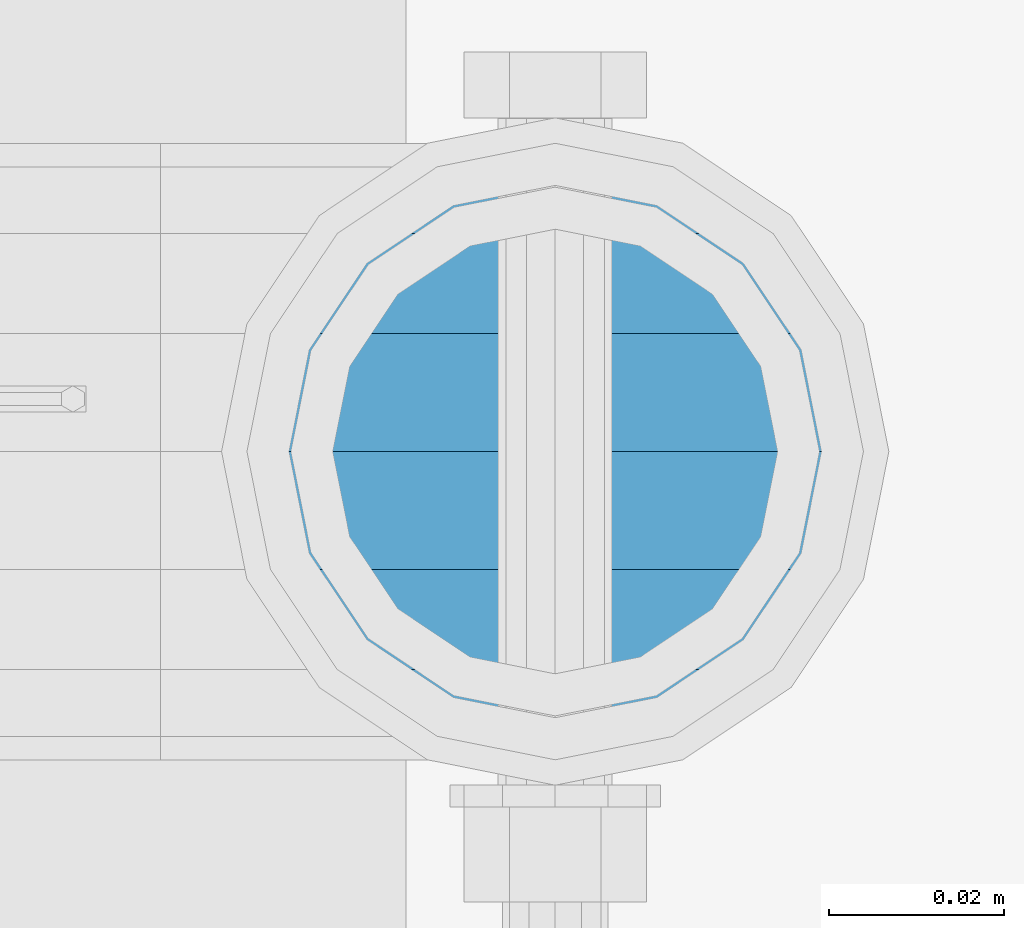
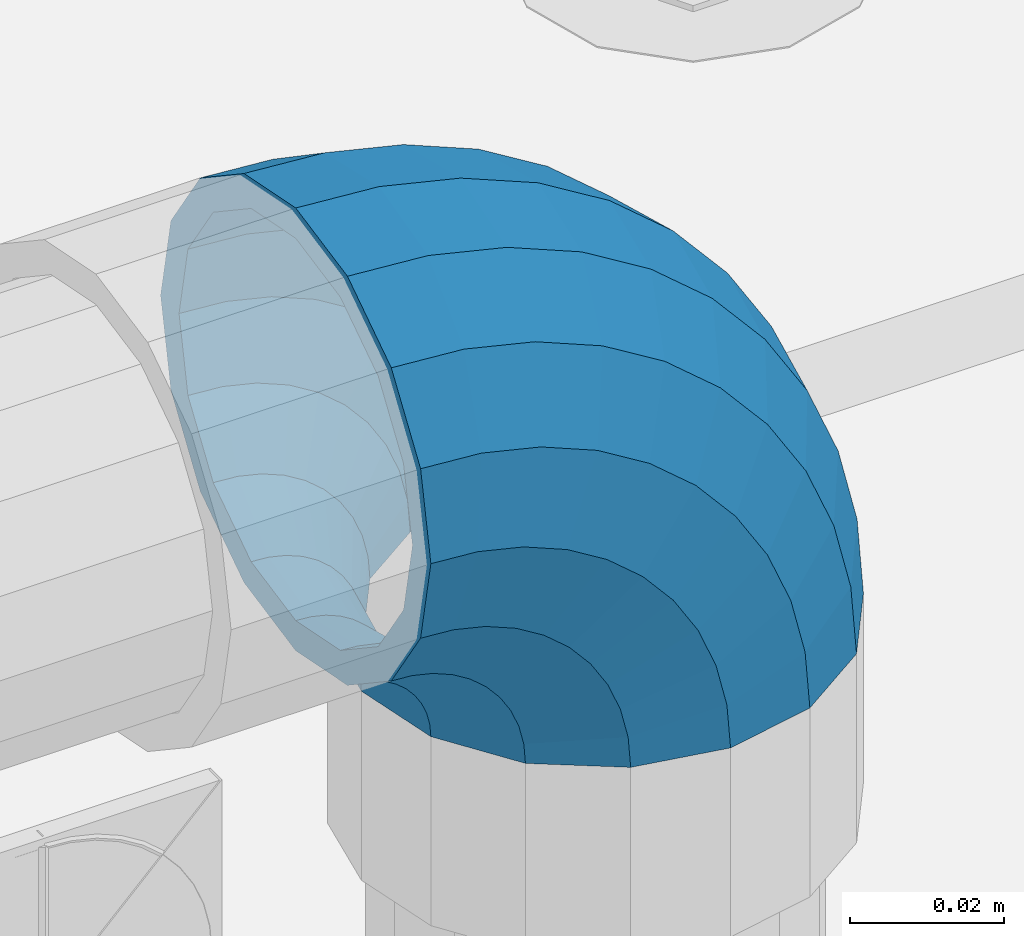
# One storey, part 159 of 240: 1 member.
"""IFC2X3 building model written with IfcOpenShell, lengths in millimetres."""

from ifc_helpers import new_model, si_unit, frame, origin_with_axes, place, context, subcontext, project, spatial, faceted_brep, material, type_object, element, save


model = new_model("IFC2X3")

# Units and contexts
model_context = context("Model", 3, precision=1e-05, world=origin_with_axes())
body_context = subcontext(model_context, "Body", "Model", "MODEL_VIEW")
ifc_project = project(units=[si_unit("LENGTHUNIT", "METRE", prefix="MILLI"), si_unit("AREAUNIT", "SQUARE_METRE"), si_unit("VOLUMEUNIT", "CUBIC_METRE"), si_unit("MASSUNIT", "GRAM", prefix="KILO"), si_unit("TIMEUNIT", "SECOND"), si_unit("PLANEANGLEUNIT", "RADIAN"), si_unit("SOLIDANGLEUNIT", "STERADIAN"), si_unit("THERMODYNAMICTEMPERATUREUNIT", "DEGREE_CELSIUS"), si_unit("LUMINOUSINTENSITYUNIT", "LUMEN")], contexts=[model_context])

# Site, building, storey
site_placement = place(None, origin_with_axes())
site = spatial("IfcSite", under=ifc_project, at=site_placement, CompositionType="ELEMENT")
building_placement = place(site_placement, origin_with_axes())
building = spatial("IfcBuilding", under=site, at=building_placement, Name="Standard", CompositionType="ELEMENT")
storey_placement = place(building_placement, origin_with_axes())
storey = spatial("IfcBuildingStorey", under=building, at=storey_placement, Name="Undefined", CompositionType="ELEMENT", Elevation=0.0)

# Member
ifc_material = material(Name="Misc_Undefined")
member_type = type_object("IfcMemberType", PredefinedType="NOTDEFINED")
member_placement = place(storey_placement, frame((54677.0, 34664.5, 924.85), z_axis=(0.707106781186541, -1.49999999888231e-07, 0.707106781186538), x_axis=(-0.707106781186548, 0.0, 0.707106781186548)))
element("IfcMember", 1, at=member_placement, inside=storey, type_object=member_type, material=ifc_material, context=body_context, shape_type="Brep", body=[
    faceted_brep([(0.0, -35.1500000000015, 0.0), (9.51152146006643, -32.4743655677739, -9.51152146006643), (13.2759578763362, -32.4743655677739, -6.29638902527222), (5.36946880023606, -35.1500000000015, 4.58595959348168), (17.5749999999971, -24.8548033587067, -17.5749999999971), (19.9787556631127, -24.8548033587067, -15.5219987155579), (22.9628441077002, -13.4513226476338, -22.9628441077002), (24.4574219585265, -13.4513226476338, -21.686354032383), (24.8548033587067, 0.0, -24.8548033587067), (26.0301204183124, 0.0, -23.8509877588003), (22.9628441077002, 13.4513226476338, -22.9628441077002), (24.4574219585265, 13.4513226476338, -21.686354032383), (17.5749999999971, 24.8548033587067, -17.5749999999971), (19.9787556631127, 24.8548033587067, -15.5219987155579), (9.51152146006643, 32.4743655677739, -9.51152146006643), (13.2759578763362, 32.4743655677739, -6.29638902527222), (0.0, 35.1500000000015, 0.0), (5.36946880023606, 35.1500000000015, 4.58595959348168), (-9.51152146007371, 32.4743655677739, 9.51152146007371), (-2.53702027587133, 32.4743655677739, 15.4683082122356), (-17.5749999999971, 24.8548033587067, 17.5750000000044), (-9.23981806264055, 24.8548033587067, 24.6939179025212), (-22.9628441077075, 13.4513226476338, 22.9628441077075), (-13.7184843580544, 13.4513226476338, 30.8582732193609), (-24.8548033587067, 0.0, 24.854803358714), (-15.2911828178476, 0.0, 33.0229069457637), (-22.9628441077075, -13.4513226476338, 22.9628441077075), (-13.7184843580544, -13.4513226476338, 30.8582732193609), (-17.5749999999971, -24.8548033587067, 17.5750000000044), (-9.23981806264055, -24.8548033587067, 24.6939179025212), (-9.51152146007371, -32.4743655677739, 9.51152146007371), (-2.53702027587133, -32.4743655677739, 15.4683082122356), (0.0, -30.3499999999985, 0.0), (-8.21265081971796, -28.0397438117143, 8.21265081971796), (-1.45732902223244, -28.0397438117143, 13.9822406910389), (5.36946880023606, -30.3499999999985, 4.58595959348168), (-15.1750000000029, -21.4606908090136, 15.1750000000029), (-7.24480876131565, -21.4606908090136, 21.9480231689959), (-19.8270929919963, -11.6144421722784, 19.8270929919963), (-11.1118790903492, -11.6144421722784, 27.2705888550845), (-21.4606908090136, 0.0, 21.4606908090136), (-12.46981360684, 0.0, 29.139625372758), (-19.8270929919963, 11.6144421722784, 19.8270929919963), (-11.1118790903492, 11.6144421722784, 27.2705888550845), (-15.1750000000029, 21.4606908090136, 15.1750000000029), (-7.24480876131565, 21.4606908090136, 21.9480231689959), (-8.21265081971796, 28.0397438117143, 8.21265081971796), (-1.45732902223244, 28.0397438117143, 13.9822406910389), (0.0, 30.3499999999985, 0.0), (5.36946880023606, 30.3499999999985, 4.58595959348168), (8.21265081971796, 28.0397438117143, -8.21265081971796), (12.1962666227046, 28.0397438117143, -4.81032150407555), (15.1750000000029, 21.4606908090136, -15.1749999999956), (17.9837463617805, 21.4606908090136, -12.7761039820398), (19.8270929919963, 11.6144421722784, -19.8270929919963), (21.8508166908287, 11.6144421722784, -18.0986696681139), (21.4606908090136, 0.0, -21.4606908090063), (23.2087512073122, 0.0, -19.9677061857947), (19.8270929919963, -11.6144421722784, -19.8270929919963), (21.8508166908287, -11.6144421722784, -18.0986696681139), (15.1750000000029, -21.4606908090136, -15.1749999999956), (17.9837463617805, -21.4606908090136, -12.7761039820398), (8.21265081971796, -28.0397438117143, -8.21265081971796), (12.1962666227046, -28.0397438117143, -4.81032150407555), (17.4970053560755, -32.4743655677739, -3.70972780291777), (11.390232665115, -35.1500000000015, 8.27548843508703), (22.6740772628618, -24.8548033587067, -13.8703035149447), (26.1332861179544, -13.4513226476338, -20.6593831546707), (27.347998730962, 0.0, -23.0433908901396), (26.1332861179544, 13.4513226476338, -20.6593831546707), (22.6740772628618, 24.8548033587067, -13.8703035149447), (17.4970053560755, 32.4743655677739, -3.70972780291777), (11.390232665115, 35.1500000000015, 8.27548843508703), (5.28345997416181, 32.4743655677739, 20.2607046730918), (0.106388067375519, 24.8548033587067, 30.4212803851042), (-3.35282078771706, 13.4513226476338, 37.210360024852), (-4.56753340072464, 0.0, 39.5943677603063), (-3.35282078771706, -13.4513226476338, 37.210360024852), (0.106388067375519, -24.8548033587067, 30.4212803851042), (5.28345997416181, -32.4743655677739, 20.2607046730918), (6.11738625913131, -28.0397438117143, 18.6240321853984), (11.390232665115, -30.3499999999985, 8.27548843508703), (1.64728291997744, -21.4606908090136, 27.3971039595053), (-1.33954464053386, -11.6144421722784, 33.2590831078996), (-2.38837900197541, 0.0, 35.3175364442068), (-1.33954464053386, 11.6144421722784, 33.2590831078996), (1.64728291997744, 21.4606908090136, 27.3971039595053), (6.11738625913131, 28.0397438117143, 18.6240321853984), (11.390232665115, 30.3499999999985, 8.27548843508703), (16.663079071106, 28.0397438117143, -2.07305531522434), (21.1331824102599, 21.4606908090136, -10.8461270893313), (24.1200099707639, 11.6144421722784, -16.7081062377256), (25.1688443322128, 0.0, -18.7665595740255), (24.1200099707639, -11.6144421722784, -16.7081062377256), (21.1331824102599, -21.4606908090136, -10.8461270893313), (16.663079071106, -28.0397438117143, -2.07305531522434), (22.070727701459, -32.4743655677739, -1.81522997692809), (17.9140404065256, -35.1500000000015, 10.9777380798914), (25.5945970362081, -24.8548033587067, -12.6605846156453), (27.9491712485105, -13.4513226476338, -19.9072189058861), (28.7759877588032, 0.0, -22.4518984678798), (27.9491712485105, 13.4513226476338, -19.9072189058861), (25.5945970362081, 24.8548033587067, -12.6605846156453), (22.070727701459, 32.4743655677739, -1.81522997692809), (17.9140404065256, 35.1500000000015, 10.9777380798914), (13.7573531115777, 32.4743655677739, 23.7707061367109), (10.2334837768358, 24.8548033587067, 34.6160607754209), (7.87890956454066, 13.4513226476338, 41.862695065669), (7.05209305424796, 0.0, 44.4073746276699), (7.87890956454066, -13.4513226476338, 41.862695065669), (10.2334837768358, -24.8548033587067, 34.6160607754209), (13.7573531115777, -32.4743655677739, 23.7707061367109), (14.3249803951039, -28.0397438117143, 22.023728990971), (17.9140404065256, -30.3499999999985, 10.9777380798914), (11.2823222355146, -21.4606908090136, 31.3880679180002), (9.24928305078356, -11.6144421722784, 37.6451191472734), (8.53537462724489, 0.0, 39.8423033494473), (9.24928305078356, 11.6144421722784, 37.6451191472734), (11.2823222355146, 21.4606908090136, 31.3880679180002), (14.3249803951039, 28.0397438117143, 22.023728990971), (17.9140404065256, 30.3499999999985, 10.9777380798914), (21.5031004179473, 28.0397438117143, -0.0682528311954229), (24.5457585775293, 21.4606908090136, -9.43259175821731), (26.5787977622676, 11.6144421722784, -15.6896429874905), (27.2927061858063, 0.0, -17.8868271896717), (26.5787977622676, -11.6144421722784, -15.6896429874905), (24.5457585775293, -21.4606908090136, -9.43259175821731), (21.5031004179473, -28.0397438117143, -0.0682528311954229), (26.8845046890492, -32.4743655677739, -0.659544371257653), (24.7802542265854, -35.1500000000015, 12.6261701733893), (28.6684020936882, -24.8548033587067, -11.9226293117827), (29.860364231703, -13.4513226476338, -19.4483820661189), (30.2789256727556, 0.0, -22.0910749985269), (29.860364231703, 13.4513226476338, -19.4483820661189), (28.6684020936882, 24.8548033587067, -11.9226293117827), (26.8845046890492, 32.4743655677739, -0.659544371257653), (24.7802542265854, 35.1500000000015, 12.6261701733893), (22.6760037641216, 32.4743655677739, 25.9118847180362), (20.8921063594826, 24.8548033587067, 37.1749696585684), (19.7001442214678, 13.4513226476338, 44.7007224129047), (19.2815827804225, 0.0, 47.3434153453127), (19.7001442214678, -13.4513226476338, 44.7007224129047), (20.8921063594826, -24.8548033587067, 37.1749696585684), (22.6760037641216, -32.4743655677739, 25.9118847180362), (22.9633551786319, -28.0397438117143, 24.0976192894668), (24.7802542265854, -30.3499999999985, 12.6261701733893), (21.4230625404889, -21.4606908090136, 33.8226442665691), (20.3938719035359, -11.6144421722784, 40.3206982095071), (20.0324682126156, 0.0, 42.6025113104479), (20.3938719035359, 11.6144421722784, 40.3206982095071), (21.4230625404889, 21.4606908090136, 33.8226442665691), (22.9633551786319, 28.0397438117143, 24.0976192894668), (24.7802542265854, 30.3499999999985, 12.6261701733893), (26.5971532745461, 28.0397438117143, 1.15472105731169), (28.1374459126891, 21.4606908090136, -8.57030391978333), (29.1666365496349, 11.6144421722784, -15.0683578627213), (29.5280402405551, 0.0, -17.3501709636694), (29.1666365496349, -11.6144421722784, -15.0683578627213), (28.1374459126891, -21.4606908090136, -8.57030391978333), (26.5971532745461, -28.0397438117143, 1.15472105731169), (31.8198051533982, -32.4743655677739, -0.271127801024704), (31.8198051533909, -35.1500000000015, 13.1801948466091), (31.8198051533982, -24.8548033587067, -11.6746085120976), (31.8198051533909, -13.4513226476338, -19.2941707211648), (31.8198051533982, 0.0, -21.9698051533924), (31.8198051533909, 13.4513226476338, -19.2941707211648), (31.8198051533982, 24.8548033587067, -11.6746085120976), (31.8198051533982, 32.4743655677739, -0.271127801024704), (31.8198051533909, 35.1500000000015, 13.1801948466091), (31.8198051533982, 32.4743655677739, 26.6315174942429), (31.8198051533982, 24.8548033587067, 38.0349982053158), (31.8198051533909, 13.4513226476338, 45.654560414383), (31.8198051533982, 0.0, 48.3301948466178), (31.8198051533909, -13.4513226476338, 45.654560414383), (31.8198051533982, -24.8548033587067, 38.0349982053158), (31.8198051533982, -32.4743655677739, 26.6315174942429), (31.8198051533982, -28.0397438117143, 24.7946370188947), (31.8198051533909, -30.3499999999985, 13.1801948466091), (31.8198051533982, -21.4606908090136, 34.6408856556227), (31.8198051533982, -11.6144421722784, 41.2199386583306), (31.8198051533982, 0.0, 43.5301948466076), (31.8198051533982, 11.6144421722784, 41.2199386583306), (31.8198051533982, 21.4606908090136, 34.6408856556227), (31.8198051533982, 28.0397438117143, 24.7946370188947), (31.8198051533909, 30.3499999999985, 13.1801948466091), (31.8198051533982, 28.0397438117143, 1.56575267433072), (31.8198051533982, 21.4606908090136, -8.28049596239725), (31.8198051533982, 11.6144421722784, -14.8595489651125), (31.8198051533982, 0.0, -17.1698051533895), (31.8198051533982, -11.6144421722784, -14.8595489651125), (31.8198051533982, -21.4606908090136, -8.28049596239725), (31.8198051533982, -28.0397438117143, 1.56575267433072), (36.7551056177399, -32.4743655677739, -0.659544371264928), (38.859356080211, -35.1500000000015, 12.6261701733965), (34.9712082131082, -24.8548033587067, -11.9226293117899), (33.7792460750934, -13.4513226476338, -19.4483820661189), (33.3606846340408, 0.0, -22.0910749985342), (33.7792460750934, 13.4513226476338, -19.4483820661189), (34.9712082131082, 24.8548033587067, -11.9226293117899), (36.7551056177399, 32.4743655677739, -0.659544371264928), (38.859356080211, 35.1500000000015, 12.6261701733965), (40.9636065426675, 32.4743655677739, 25.9118847180434), (42.7475039473065, 24.8548033587067, 37.1749696585684), (43.9394660853213, 13.4513226476338, 44.7007224129047), (44.3580275263739, 0.0, 47.3434153453054), (43.9394660853213, -13.4513226476338, 44.7007224129047), (42.7475039473065, -24.8548033587067, 37.1749696585684), (40.9636065426675, -32.4743655677739, 25.9118847180434), (40.6762551281645, -28.0397438117143, 24.0976192894668), (38.859356080211, -30.3499999999985, 12.6261701733965), (42.2165477663075, -21.4606908090136, 33.8226442665691), (43.2457384032605, -11.6144421722784, 40.3206982094998), (43.6071420941807, 0.0, 42.6025113104552), (43.2457384032605, 11.6144421722784, 40.3206982094998), (42.2165477663075, 21.4606908090136, 33.8226442665691), (40.6762551281645, 28.0397438117143, 24.0976192894668), (38.859356080211, 30.3499999999985, 12.6261701733965), (37.042457032243, 28.0397438117143, 1.15472105731169), (35.5021643941072, 21.4606908090136, -8.57030391978333), (34.4729737571543, 11.6144421722784, -15.068357862714), (34.111570066234, 0.0, -17.3501709636694), (34.4729737571543, -11.6144421722784, -15.068357862714), (35.5021643941072, -21.4606908090136, -8.57030391978333), (37.042457032243, -28.0397438117143, 1.15472105731169), (41.5688826053301, -32.4743655677739, -1.81522997692809), (45.7255699002708, -35.1500000000015, 10.9777380798987), (38.0450132705882, -24.8548033587067, -12.6605846156381), (35.6904390582786, -13.4513226476338, -19.9072189058934), (34.8636225479859, 0.0, -22.4518984678871), (35.6904390582786, 13.4513226476338, -19.9072189058934), (38.0450132705882, 24.8548033587067, -12.6605846156381), (41.5688826053301, 32.4743655677739, -1.81522997692809), (45.7255699002708, 35.1500000000015, 10.9777380798987), (49.8822571952041, 32.4743655677739, 23.7707061367109), (53.4061265299533, 24.8548033587067, 34.6160607754282), (55.7607007422557, 13.4513226476338, 41.862695065669), (56.5875172525484, 0.0, 44.4073746276626), (55.7607007422557, -13.4513226476338, 41.862695065669), (53.4061265299533, -24.8548033587067, 34.6160607754282), (49.8822571952041, -32.4743655677739, 23.7707061367109), (49.3146299116925, -28.0397438117143, 22.023728990971), (45.7255699002708, -30.3499999999985, 10.9777380798987), (52.3572880712745, -21.4606908090136, 31.3880679180002), (54.3903272560128, -11.6144421722784, 37.6451191472734), (55.1042356795515, 0.0, 39.8423033494473), (54.3903272560128, 11.6144421722784, 37.6451191472734), (52.3572880712745, 21.4606908090136, 31.3880679180002), (49.3146299116925, 28.0397438117143, 22.023728990971), (45.7255699002708, 30.3499999999985, 10.9777380798987), (42.1365098888491, 28.0397438117143, -0.068252831188147), (39.0938517292598, 21.4606908090136, -9.43259175821731), (37.0608125445287, 11.6144421722784, -15.6896429874905), (36.3469041209901, 0.0, -17.8868271896645), (37.0608125445287, -11.6144421722784, -15.6896429874905), (39.0938517292598, -21.4606908090136, -9.43259175821731), (42.1365098888491, -28.0397438117143, -0.068252831188147), (46.1426049507209, -32.4743655677739, -3.70972780291777), (52.2493776416741, -35.1500000000015, 8.27548843508703), (40.9655330439346, -24.8548033587067, -13.8703035149374), (37.506324188842, -13.4513226476338, -20.6593831546707), (36.2916115758271, 0.0, -23.0433908901323), (37.506324188842, 13.4513226476338, -20.6593831546707), (40.9655330439346, 24.8548033587067, -13.8703035149374), (46.1426049507209, 32.4743655677739, -3.70972780291777), (52.2493776416741, 35.1500000000015, 8.27548843508703), (58.3561503326346, 32.4743655677739, 20.2607046730918), (63.5332222394209, 24.8548033587067, 30.4212803851115), (66.9924310945134, 13.4513226476338, 37.2103600248447), (68.207143707521, 0.0, 39.5943677603063), (66.9924310945134, -13.4513226476338, 37.2103600248447), (63.5332222394209, -24.8548033587067, 30.4212803851115), (58.3561503326346, -32.4743655677739, 20.2607046730918), (57.5222240476651, -28.0397438117143, 18.6240321853984), (52.2493776416741, -30.3499999999985, 8.27548843508703), (61.9923273868189, -21.4606908090136, 27.3971039594981), (64.979154947323, -11.6144421722784, 33.2590831078924), (66.0279893087718, 0.0, 35.3175364442068), (64.979154947323, 11.6144421722784, 33.2590831078924), (61.9923273868189, 21.4606908090136, 27.3971039594981), (57.5222240476651, 28.0397438117143, 18.6240321853984), (52.2493776416741, 30.3499999999985, 8.27548843508703), (46.9765312356903, 28.0397438117143, -2.07305531523161), (42.5064278965365, 21.4606908090136, -10.8461270893313), (39.5196003360252, 11.6144421722784, -16.7081062377256), (38.4707659745836, 0.0, -18.7665595740327), (39.5196003360252, -11.6144421722784, -16.7081062377256), (42.5064278965365, -21.4606908090136, -10.8461270893313), (46.9765312356903, -28.0397438117143, -2.07305531523161), (50.3636524304529, -32.4743655677739, -6.2963890252795), (58.2701415065603, -35.1500000000015, 4.58595959348895), (43.6608546436837, -24.8548033587067, -15.5219987155579), (39.1821883482698, -13.4513226476338, -21.6863540323902), (37.6094898884767, 0.0, -23.8509877587931), (39.1821883482698, 13.4513226476338, -21.6863540323902), (43.6608546436837, 24.8548033587067, -15.5219987155579), (50.3636524304529, 32.4743655677739, -6.2963890252795), (58.2701415065603, 35.1500000000015, 4.58595959348895), (66.1766305826604, 32.4743655677739, 15.4683082122356), (72.8794283694297, 24.8548033587067, 24.6939179025212), (77.3580946648508, 13.4513226476338, 30.8582732193536), (78.9307931246367, 0.0, 33.0229069457637), (77.3580946648508, -13.4513226476338, 30.8582732193536), (72.8794283694297, -24.8548033587067, 24.6939179025212), (66.1766305826604, -32.4743655677739, 15.4683082122356), (65.0969393290288, -28.0397438117143, 13.9822406910462), (58.2701415065603, -30.3499999999985, 4.58595959348895), (70.884419068112, -21.4606908090136, 21.9480231689959), (74.7514893971456, -11.6144421722784, 27.2705888550845), (76.1094239136364, 0.0, 29.139625372758), (74.7514893971456, 11.6144421722784, 27.2705888550845), (70.884419068112, 21.4606908090136, 21.9480231689959), (65.0969393290288, 28.0397438117143, 13.9822406910462), (58.2701415065603, 30.3499999999985, 4.58595959348895), (51.4433436840845, 28.0397438117143, -4.81032150407555), (45.6558639450086, 21.4606908090136, -12.7761039820325), (41.7887936159677, 11.6144421722784, -18.0986696681211), (40.4308590994842, 0.0, -19.9677061858019), (41.7887936159677, -11.6144421722784, -18.0986696681211), (45.6558639450086, -21.4606908090136, -12.7761039820325), (51.4433436840845, -28.0397438117143, -4.81032150407555), (54.1280888467154, -32.4743655677739, -9.51152146006643), (63.6396103067891, -35.1500000000015, 7.27595761418343e-12), (46.0646103067847, -24.8548033587067, -17.5749999999971), (40.6767661990889, -13.4513226476338, -22.9628441077002), (38.7848069480824, 0.0, -24.8548033586994), (40.6767661990889, 13.4513226476338, -22.9628441077002), (46.0646103067847, 24.8548033587067, -17.5749999999971), (54.1280888467154, 32.4743655677739, -9.51152146006643), (63.6396103067891, 35.1500000000015, 7.27595761418343e-12), (73.1511317668555, 32.4743655677739, 9.51152146007371), (81.2146103067862, 24.8548033587067, 17.5750000000044), (86.6024544144893, 13.4513226476338, 22.9628441077075), (88.4944136654958, 0.0, 24.854803358714), (86.6024544144893, -13.4513226476338, 22.9628441077075), (81.2146103067862, -24.8548033587067, 17.5750000000044), (73.1511317668555, -32.4743655677739, 9.51152146007371), (71.8522611265071, -28.0397438117143, 8.21265081972524), (63.6396103067891, -30.3499999999985, 7.27595761418343e-12), (78.8146103067847, -21.4606908090136, 15.1750000000029), (83.4667032987854, -11.6144421722784, 19.8270929920036), (85.1003011158027, 0.0, 21.4606908090136), (83.4667032987854, 11.6144421722784, 19.8270929920036), (78.8146103067847, 21.4606908090136, 15.1750000000029), (71.8522611265071, 28.0397438117143, 8.21265081972524), (63.6396103067891, 30.3499999999985, 7.27595761418343e-12), (55.4269594870711, 28.0397438117143, -8.21265081971069), (48.4646103067862, 21.4606908090136, -15.1749999999956), (43.8125173147855, 11.6144421722784, -19.8270929919963), (42.1789194977755, 0.0, -21.4606908090063), (43.8125173147855, -11.6144421722784, -19.8270929919963), (48.4646103067862, -21.4606908090136, -15.1749999999956), (55.4269594870711, -28.0397438117143, -8.21265081971069)], [[[0, 1, 2, 3]], [[1, 4, 5, 2]], [[4, 6, 7, 5]], [[6, 8, 9, 7]], [[8, 10, 11, 9]], [[10, 12, 13, 11]], [[12, 14, 15, 13]], [[14, 16, 17, 15]], [[16, 18, 19, 17]], [[18, 20, 21, 19]], [[20, 22, 23, 21]], [[22, 24, 25, 23]], [[24, 26, 27, 25]], [[26, 28, 29, 27]], [[28, 30, 31, 29]], [[30, 0, 3, 31]], [[32, 33, 34, 35]], [[33, 36, 37, 34]], [[36, 38, 39, 37]], [[38, 40, 41, 39]], [[40, 42, 43, 41]], [[42, 44, 45, 43]], [[44, 46, 47, 45]], [[46, 48, 49, 47]], [[48, 50, 51, 49]], [[50, 52, 53, 51]], [[52, 54, 55, 53]], [[54, 56, 57, 55]], [[56, 58, 59, 57]], [[58, 60, 61, 59]], [[60, 62, 63, 61]], [[62, 32, 35, 63]], [[30, 28, 26, 24, 22, 20, 18, 16, 14, 12, 10, 8, 6, 4, 1, 0], [62, 60, 58, 56, 54, 52, 50, 48, 46, 44, 42, 40, 38, 36, 33, 32]], [[3, 2, 64, 65]], [[2, 5, 66, 64]], [[5, 7, 67, 66]], [[7, 9, 68, 67]], [[9, 11, 69, 68]], [[11, 13, 70, 69]], [[13, 15, 71, 70]], [[15, 17, 72, 71]], [[17, 19, 73, 72]], [[19, 21, 74, 73]], [[21, 23, 75, 74]], [[23, 25, 76, 75]], [[25, 27, 77, 76]], [[27, 29, 78, 77]], [[29, 31, 79, 78]], [[31, 3, 65, 79]], [[35, 34, 80, 81]], [[34, 37, 82, 80]], [[37, 39, 83, 82]], [[39, 41, 84, 83]], [[41, 43, 85, 84]], [[43, 45, 86, 85]], [[45, 47, 87, 86]], [[47, 49, 88, 87]], [[49, 51, 89, 88]], [[51, 53, 90, 89]], [[53, 55, 91, 90]], [[55, 57, 92, 91]], [[57, 59, 93, 92]], [[59, 61, 94, 93]], [[61, 63, 95, 94]], [[63, 35, 81, 95]], [[65, 64, 96, 97]], [[64, 66, 98, 96]], [[66, 67, 99, 98]], [[67, 68, 100, 99]], [[68, 69, 101, 100]], [[69, 70, 102, 101]], [[70, 71, 103, 102]], [[71, 72, 104, 103]], [[72, 73, 105, 104]], [[73, 74, 106, 105]], [[74, 75, 107, 106]], [[75, 76, 108, 107]], [[76, 77, 109, 108]], [[77, 78, 110, 109]], [[78, 79, 111, 110]], [[79, 65, 97, 111]], [[81, 80, 112, 113]], [[80, 82, 114, 112]], [[82, 83, 115, 114]], [[83, 84, 116, 115]], [[84, 85, 117, 116]], [[85, 86, 118, 117]], [[86, 87, 119, 118]], [[87, 88, 120, 119]], [[88, 89, 121, 120]], [[89, 90, 122, 121]], [[90, 91, 123, 122]], [[91, 92, 124, 123]], [[92, 93, 125, 124]], [[93, 94, 126, 125]], [[94, 95, 127, 126]], [[95, 81, 113, 127]], [[97, 96, 128, 129]], [[96, 98, 130, 128]], [[98, 99, 131, 130]], [[99, 100, 132, 131]], [[100, 101, 133, 132]], [[101, 102, 134, 133]], [[102, 103, 135, 134]], [[103, 104, 136, 135]], [[104, 105, 137, 136]], [[105, 106, 138, 137]], [[106, 107, 139, 138]], [[107, 108, 140, 139]], [[108, 109, 141, 140]], [[109, 110, 142, 141]], [[110, 111, 143, 142]], [[111, 97, 129, 143]], [[113, 112, 144, 145]], [[112, 114, 146, 144]], [[114, 115, 147, 146]], [[115, 116, 148, 147]], [[116, 117, 149, 148]], [[117, 118, 150, 149]], [[118, 119, 151, 150]], [[119, 120, 152, 151]], [[120, 121, 153, 152]], [[121, 122, 154, 153]], [[122, 123, 155, 154]], [[123, 124, 156, 155]], [[124, 125, 157, 156]], [[125, 126, 158, 157]], [[126, 127, 159, 158]], [[127, 113, 145, 159]], [[129, 128, 160, 161]], [[128, 130, 162, 160]], [[130, 131, 163, 162]], [[131, 132, 164, 163]], [[132, 133, 165, 164]], [[133, 134, 166, 165]], [[134, 135, 167, 166]], [[135, 136, 168, 167]], [[136, 137, 169, 168]], [[137, 138, 170, 169]], [[138, 139, 171, 170]], [[139, 140, 172, 171]], [[140, 141, 173, 172]], [[141, 142, 174, 173]], [[142, 143, 175, 174]], [[143, 129, 161, 175]], [[145, 144, 176, 177]], [[144, 146, 178, 176]], [[146, 147, 179, 178]], [[147, 148, 180, 179]], [[148, 149, 181, 180]], [[149, 150, 182, 181]], [[150, 151, 183, 182]], [[151, 152, 184, 183]], [[152, 153, 185, 184]], [[153, 154, 186, 185]], [[154, 155, 187, 186]], [[155, 156, 188, 187]], [[156, 157, 189, 188]], [[157, 158, 190, 189]], [[158, 159, 191, 190]], [[159, 145, 177, 191]], [[161, 160, 192, 193]], [[160, 162, 194, 192]], [[162, 163, 195, 194]], [[163, 164, 196, 195]], [[164, 165, 197, 196]], [[165, 166, 198, 197]], [[166, 167, 199, 198]], [[167, 168, 200, 199]], [[168, 169, 201, 200]], [[169, 170, 202, 201]], [[170, 171, 203, 202]], [[171, 172, 204, 203]], [[172, 173, 205, 204]], [[173, 174, 206, 205]], [[174, 175, 207, 206]], [[175, 161, 193, 207]], [[177, 176, 208, 209]], [[176, 178, 210, 208]], [[178, 179, 211, 210]], [[179, 180, 212, 211]], [[180, 181, 213, 212]], [[181, 182, 214, 213]], [[182, 183, 215, 214]], [[183, 184, 216, 215]], [[184, 185, 217, 216]], [[185, 186, 218, 217]], [[186, 187, 219, 218]], [[187, 188, 220, 219]], [[188, 189, 221, 220]], [[189, 190, 222, 221]], [[190, 191, 223, 222]], [[191, 177, 209, 223]], [[193, 192, 224, 225]], [[192, 194, 226, 224]], [[194, 195, 227, 226]], [[195, 196, 228, 227]], [[196, 197, 229, 228]], [[197, 198, 230, 229]], [[198, 199, 231, 230]], [[199, 200, 232, 231]], [[200, 201, 233, 232]], [[201, 202, 234, 233]], [[202, 203, 235, 234]], [[203, 204, 236, 235]], [[204, 205, 237, 236]], [[205, 206, 238, 237]], [[206, 207, 239, 238]], [[207, 193, 225, 239]], [[209, 208, 240, 241]], [[208, 210, 242, 240]], [[210, 211, 243, 242]], [[211, 212, 244, 243]], [[212, 213, 245, 244]], [[213, 214, 246, 245]], [[214, 215, 247, 246]], [[215, 216, 248, 247]], [[216, 217, 249, 248]], [[217, 218, 250, 249]], [[218, 219, 251, 250]], [[219, 220, 252, 251]], [[220, 221, 253, 252]], [[221, 222, 254, 253]], [[222, 223, 255, 254]], [[223, 209, 241, 255]], [[225, 224, 256, 257]], [[224, 226, 258, 256]], [[226, 227, 259, 258]], [[227, 228, 260, 259]], [[228, 229, 261, 260]], [[229, 230, 262, 261]], [[230, 231, 263, 262]], [[231, 232, 264, 263]], [[232, 233, 265, 264]], [[233, 234, 266, 265]], [[234, 235, 267, 266]], [[235, 236, 268, 267]], [[236, 237, 269, 268]], [[237, 238, 270, 269]], [[238, 239, 271, 270]], [[239, 225, 257, 271]], [[241, 240, 272, 273]], [[240, 242, 274, 272]], [[242, 243, 275, 274]], [[243, 244, 276, 275]], [[244, 245, 277, 276]], [[245, 246, 278, 277]], [[246, 247, 279, 278]], [[247, 248, 280, 279]], [[248, 249, 281, 280]], [[249, 250, 282, 281]], [[250, 251, 283, 282]], [[251, 252, 284, 283]], [[252, 253, 285, 284]], [[253, 254, 286, 285]], [[254, 255, 287, 286]], [[255, 241, 273, 287]], [[257, 256, 288, 289]], [[256, 258, 290, 288]], [[258, 259, 291, 290]], [[259, 260, 292, 291]], [[260, 261, 293, 292]], [[261, 262, 294, 293]], [[262, 263, 295, 294]], [[263, 264, 296, 295]], [[264, 265, 297, 296]], [[265, 266, 298, 297]], [[266, 267, 299, 298]], [[267, 268, 300, 299]], [[268, 269, 301, 300]], [[269, 270, 302, 301]], [[270, 271, 303, 302]], [[271, 257, 289, 303]], [[273, 272, 304, 305]], [[272, 274, 306, 304]], [[274, 275, 307, 306]], [[275, 276, 308, 307]], [[276, 277, 309, 308]], [[277, 278, 310, 309]], [[278, 279, 311, 310]], [[279, 280, 312, 311]], [[280, 281, 313, 312]], [[281, 282, 314, 313]], [[282, 283, 315, 314]], [[283, 284, 316, 315]], [[284, 285, 317, 316]], [[285, 286, 318, 317]], [[286, 287, 319, 318]], [[287, 273, 305, 319]], [[289, 288, 320, 321]], [[288, 290, 322, 320]], [[290, 291, 323, 322]], [[291, 292, 324, 323]], [[292, 293, 325, 324]], [[293, 294, 326, 325]], [[294, 295, 327, 326]], [[295, 296, 328, 327]], [[296, 297, 329, 328]], [[297, 298, 330, 329]], [[298, 299, 331, 330]], [[299, 300, 332, 331]], [[300, 301, 333, 332]], [[301, 302, 334, 333]], [[302, 303, 335, 334]], [[303, 289, 321, 335]], [[305, 304, 336, 337]], [[304, 306, 338, 336]], [[306, 307, 339, 338]], [[307, 308, 340, 339]], [[308, 309, 341, 340]], [[309, 310, 342, 341]], [[310, 311, 343, 342]], [[311, 312, 344, 343]], [[312, 313, 345, 344]], [[313, 314, 346, 345]], [[314, 315, 347, 346]], [[315, 316, 348, 347]], [[316, 317, 349, 348]], [[317, 318, 350, 349]], [[318, 319, 351, 350]], [[319, 305, 337, 351]], [[322, 323, 324, 325, 326, 327, 328, 329, 330, 331, 332, 333, 334, 335, 321, 320], [338, 339, 340, 341, 342, 343, 344, 345, 346, 347, 348, 349, 350, 351, 337, 336]]]),
])

save(model, "model.ifc")
